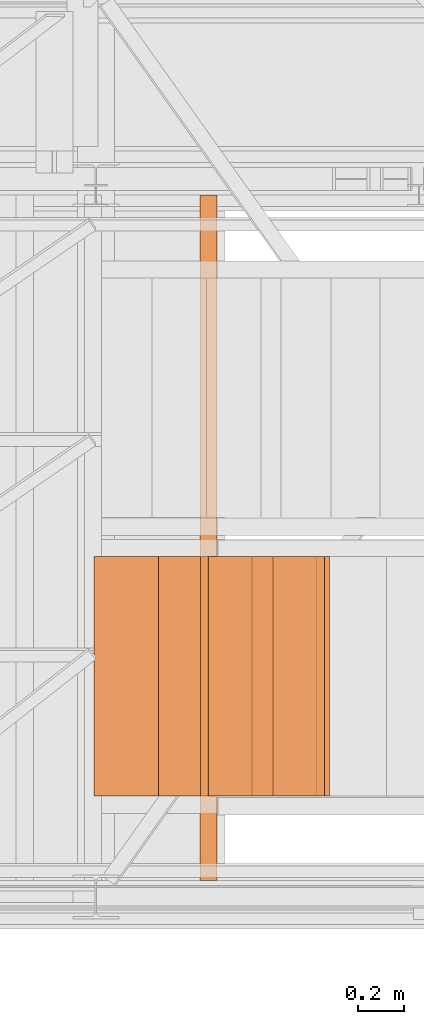
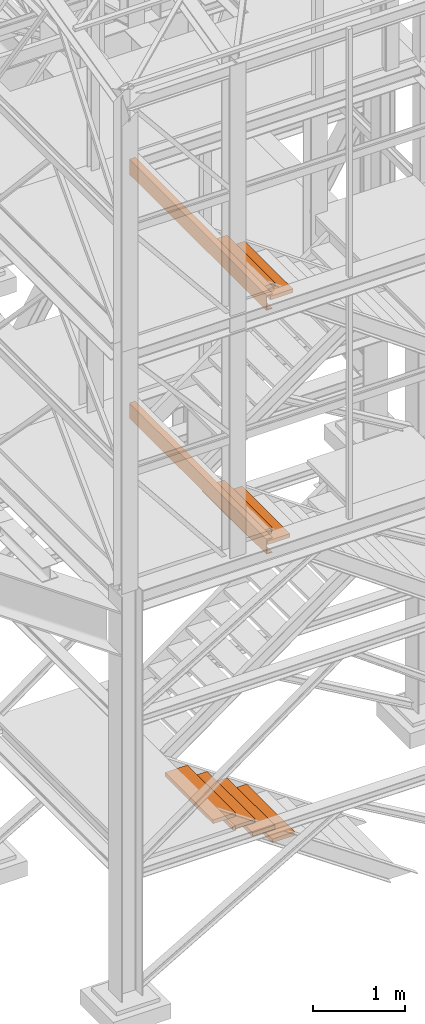
# One storey, part 10 of 208: 10 proxies.
"""IFC2X3 building model written with IfcOpenShell, lengths in millimetres."""

from ifc_helpers import new_model, entity, si_unit, converted_unit, frame, origin, origin_with_axes, place, context, subcontext, project, spatial, faceted_brep, element, save


model = new_model("IFC2X3")

# Units and contexts
model_context = context("Model", 3, precision=1e-05, world=origin())
plan_context = context("Plan", 3, precision=1e-05, world=origin())
body_context = subcontext(model_context, "Body", "Model", "MODEL_VIEW")
ifc_project = project(units=[si_unit("LENGTHUNIT", "METRE", prefix="MILLI"), converted_unit("PLANEANGLEUNIT", "DEGREE", entity("IfcPlaneAngleMeasure", 0.0174532925199433), si_unit("PLANEANGLEUNIT", "RADIAN"), dimensions=[0, 0, 0, 0, 0, 0, 0]), si_unit("AREAUNIT", "SQUARE_METRE"), si_unit("VOLUMEUNIT", "CUBIC_METRE")], contexts=[model_context, plan_context])

# Building, storey
building_placement = place(None, origin())
building = spatial("IfcBuilding", under=ifc_project, at=building_placement, CompositionType="COMPLEX")
storey_placement = place(building_placement, origin_with_axes())
storey = spatial("IfcBuildingStorey", under=building, at=storey_placement, Name="Geschoss", CompositionType="ELEMENT")

# Proxies
proxy_1_placement = place(storey_placement, frame((2998.108527679629, -25102.57439001986, 5049.989998509882), z_axis=(0.0, 0.0, 1.0), x_axis=(1.0, 0.0, 0.0)))
element("IfcBuildingElementProxy", 1, at=proxy_1_placement, inside=storey, context=body_context, shape_type="Brep", body=[
    faceted_brep([(0.01000000000021828, 2970.009999403952, 200.0100029802325), (0.01000000000021828, 2970.009999403952, 0.01000000000021828), (75.01000111758731, 2970.009999403952, 0.01000000000021828), (75.01000111758731, 2970.009999403952, 2.97083092689536), (73.89400100171588, 2970.009999403952, 7.368834147453526), (69.48847269475482, 2970.009999403952, 8.951724896431188), (19.09293180167697, 2970.009999403952, 12.98336816787742), (13.35380079060815, 2970.009999403952, 14.57858962774299), (9.50015002697728, 2970.009999403952, 18.85888857603095), (8.510000461936215, 2970.009999403952, 24.44674206733725), (8.510000461936215, 2970.009999403952, 175.5732609128954), (9.50015002697728, 2970.009999403952, 181.1611144042017), (13.35380079060815, 2970.009999403952, 185.4414133524897), (19.09293180167697, 2970.009999403952, 187.0366348123553), (69.48847269475482, 2970.009999403952, 191.0682780838015), (73.89400100171588, 2970.009999403952, 192.6511688327792), (75.01000111758731, 2970.009999403952, 197.0491720533373), (75.01000111758731, 2970.009999403952, 200.0100029802325), (0.01000000000021828, 2970.009999403952, 0.01000000000021828), (0.01000000000021828, 2970.009999403952, 200.0100029802325), (0.01000000000021828, 0.01000000000203727, 200.0100029802325), (0.01000000000021828, 0.01000000000203727, 0.01000000000021828), (75.01000111758731, 2970.009999403952, 0.01000000000021828), (0.01000000000021828, 2970.009999403952, 0.01000000000021828), (0.01000000000021828, 0.01000000000203727, 0.01000000000021828), (75.01000111758731, 0.01000000000203727, 0.01000000000021828), (75.01000111758731, 2970.009999403952, 2.97083092689536), (75.01000111758731, 2970.009999403952, 0.01000000000021828), (75.01000111758731, 0.01000000000203727, 0.01000000000021828), (75.01000111758731, 0.01000000000203727, 2.97083092689536), (73.89400100171588, 2970.009999403952, 7.368834147453526), (75.01000111758731, 2970.009999403952, 2.97083092689536), (75.01000111758731, 0.01000000000203727, 2.97083092689536), (73.89400100171588, 0.01000000000203727, 7.368834147453526), (69.48847269475482, 2970.009999403952, 8.951724896431188), (73.89400100171588, 2970.009999403952, 7.368834147453526), (73.89400100171588, 0.01000000000203727, 7.368834147453526), (69.48847269475482, 0.01000000000203727, 8.951724896431188), (19.09293180167697, 2970.009999403952, 12.98336816787742), (69.48847269475482, 2970.009999403952, 8.951724896431188), (69.48847269475482, 0.01000000000203727, 8.951724896431188), (19.09293180167697, 0.01000000000203727, 12.98336816787742), (13.35380079060815, 2970.009999403952, 14.57858962774299), (19.09293180167697, 2970.009999403952, 12.98336816787742), (19.09293180167697, 0.01000000000203727, 12.98336816787742), (13.35380079060815, 0.01000000000203727, 14.57858962774299), (9.50015002697728, 2970.009999403952, 18.85888857603095), (13.35380079060815, 2970.009999403952, 14.57858962774299), (13.35380079060815, 0.01000000000203727, 14.57858962774299), (9.50015002697728, 0.01000000000203727, 18.85888857603095), (8.510000461936215, 2970.009999403952, 24.44674206733725), (9.50015002697728, 2970.009999403952, 18.85888857603095), (9.50015002697728, 0.01000000000203727, 18.85888857603095), (8.510000461936215, 0.01000000000203727, 24.44674206733725), (8.510000461936215, 2970.009999403952, 175.5732609128954), (8.510000461936215, 2970.009999403952, 24.44674206733725), (8.510000461936215, 0.01000000000203727, 24.44674206733725), (8.510000461936215, 0.01000000000203727, 175.5732609128954), (9.50015002697728, 2970.009999403952, 181.1611144042017), (8.510000461936215, 2970.009999403952, 175.5732609128954), (8.510000461936215, 0.01000000000203727, 175.5732609128954), (9.50015002697728, 0.01000000000203727, 181.1611144042017), (13.35380079060815, 2970.009999403952, 185.4414133524897), (9.50015002697728, 2970.009999403952, 181.1611144042017), (9.50015002697728, 0.01000000000203727, 181.1611144042017), (13.35380079060815, 0.01000000000203727, 185.4414133524897), (19.09293180167697, 2970.009999403952, 187.0366348123553), (13.35380079060815, 2970.009999403952, 185.4414133524897), (13.35380079060815, 0.01000000000203727, 185.4414133524897), (19.09293180167697, 0.01000000000203727, 187.0366348123553), (69.48847269475482, 2970.009999403952, 191.0682780838015), (19.09293180167697, 2970.009999403952, 187.0366348123553), (19.09293180167697, 0.01000000000203727, 187.0366348123553), (69.48847269475482, 0.01000000000203727, 191.0682780838015), (73.89400100171588, 2970.009999403952, 192.6511688327792), (69.48847269475482, 2970.009999403952, 191.0682780838015), (69.48847269475482, 0.01000000000203727, 191.0682780838015), (73.89400100171588, 0.01000000000203727, 192.6511688327792), (75.01000111758731, 2970.009999403952, 197.0491720533373), (73.89400100171588, 2970.009999403952, 192.6511688327792), (73.89400100171588, 0.01000000000203727, 192.6511688327792), (75.01000111758731, 0.01000000000203727, 197.0491720533373), (75.01000111758731, 2970.009999403952, 200.0100029802325), (75.01000111758731, 2970.009999403952, 197.0491720533373), (75.01000111758731, 0.01000000000203727, 197.0491720533373), (75.01000111758731, 0.01000000000203727, 200.0100029802325), (0.01000000000021828, 2970.009999403952, 200.0100029802325), (75.01000111758731, 2970.009999403952, 200.0100029802325), (75.01000111758731, 0.01000000000203727, 200.0100029802325), (0.01000000000021828, 0.01000000000203727, 200.0100029802325), (0.01000000000021828, 0.01000000000203727, 200.0100029802325), (75.01000111758731, 0.01000000000203727, 200.0100029802325), (75.01000111758731, 0.01000000000203727, 197.0491720533373), (73.89400100171588, 0.01000000000203727, 192.6511688327792), (69.48847269475482, 0.01000000000203727, 191.0682780838015), (19.09293180167697, 0.01000000000203727, 187.0366348123553), (13.35380079060815, 0.01000000000203727, 185.4414133524897), (9.50015002697728, 0.01000000000203727, 181.1611144042017), (8.510000461936215, 0.01000000000203727, 175.5732609128954), (8.510000461936215, 0.01000000000203727, 24.44674206733725), (9.50015002697728, 0.01000000000203727, 18.85888857603095), (13.35380079060815, 0.01000000000203727, 14.57858962774299), (19.09293180167697, 0.01000000000203727, 12.98336816787742), (69.48847269475482, 0.01000000000203727, 8.951724896431188), (73.89400100171588, 0.01000000000203727, 7.368834147453526), (75.01000111758731, 0.01000000000203727, 2.97083092689536), (75.01000111758731, 0.01000000000203727, 0.01000000000021828), (0.01000000000021828, 0.01000000000203727, 0.01000000000021828)], [[[0, 1, 2, 3, 4, 5, 6, 7, 8, 9, 10, 11, 12, 13, 14, 15, 16, 17]], [[18, 19, 20, 21]], [[22, 23, 24, 25]], [[26, 27, 28, 29]], [[30, 31, 32, 33]], [[34, 35, 36, 37]], [[38, 39, 40, 41]], [[42, 43, 44, 45]], [[46, 47, 48, 49]], [[50, 51, 52, 53]], [[54, 55, 56, 57]], [[58, 59, 60, 61]], [[62, 63, 64, 65]], [[66, 67, 68, 69]], [[70, 71, 72, 73]], [[74, 75, 76, 77]], [[78, 79, 80, 81]], [[82, 83, 84, 85]], [[86, 87, 88, 89]], [[90, 91, 92, 93, 94, 95, 96, 97, 98, 99, 100, 101, 102, 103, 104, 105, 106, 107]]], orient=[[False], [False], [False], [False], [False], [False], [False], [False], [False], [False], [False], [False], [False], [False], [False], [False], [False], [False], [False], [False]]),
])
for number, where, z_axis, x_axis in (
    (2, (3281.72670904966, -24736.51916887601, 919.9900010557137), (0.0, 0.0, 1.0), (1.0, 0.0, 0.0)),
    (3, (3034.506000078644, -24736.51916887601, 1089.990001055714), (0.0, 0.0, 1.0), (1.0, 0.0, 0.0)),
    (4, (2787.285291107629, -24736.51916887601, 1259.990001055714), (0.0, 0.0, 1.0), (1.0, 0.0, 0.0)),
    (5, (2540.064582136613, -24736.51916887601, 1429.990001055713), (0.0, 0.0, 1.0), (1.0, 0.0, 0.0)),
):
    element("IfcBuildingElementProxy", number, at=place(storey_placement, frame(where, z_axis=z_axis, x_axis=x_axis)), inside=storey, context=body_context, shape_type="Brep", body=[
        faceted_brep([(0.01000000000021828, 0.00999999999839929, 0.009999999999990905), (280.2746556316183, 0.00999999999839929, 0.009999999999990905), (280.2746556316183, 1037.717170711916, 0.009999999999990905), (0.01000000000021828, 1037.717170711916, 0.009999999999990905), (280.2746556316183, 0.00999999999839929, 50.00999999999999), (0.01000000000021828, 0.00999999999839929, 50.00999999999999), (0.01000000000021828, 1037.717170711916, 50.00999999999999), (280.2746556316183, 1037.717170711916, 50.00999999999999), (280.2746556316183, 0.00999999999839929, 0.009999999999990905), (0.01000000000021828, 0.00999999999839929, 0.009999999999990905), (0.01000000000021828, 0.00999999999839929, 50.00999999999999), (280.2746556316183, 0.00999999999839929, 50.00999999999999), (280.2746556316183, 1037.717170711916, 0.009999999999990905), (280.2746556316183, 0.00999999999839929, 0.009999999999990905), (280.2746556316183, 0.00999999999839929, 50.00999999999999), (280.2746556316183, 1037.717170711916, 50.00999999999999), (0.01000000000021828, 1037.717170711916, 0.009999999999990905), (280.2746556316183, 1037.717170711916, 0.009999999999990905), (280.2746556316183, 1037.717170711916, 50.00999999999999), (0.01000000000021828, 1037.717170711916, 50.00999999999999), (0.01000000000021828, 0.00999999999839929, 0.009999999999990905), (0.01000000000021828, 1037.717170711916, 0.009999999999990905), (0.01000000000021828, 1037.717170711916, 50.00999999999999), (0.01000000000021828, 0.00999999999839929, 50.00999999999999)], [[[0, 1, 2, 3]], [[4, 5, 6, 7]], [[8, 9, 10, 11]], [[12, 13, 14, 15]], [[16, 17, 18, 19]], [[20, 21, 22, 23]]], orient=[[False], [False], [False], [False], [False], [False]]),
    ])
for number, where, z_axis, x_axis in (
    (6, (3223.286924024275, -24736.51916887601, 4877.039372824652), (0.0, 0.0, 1.0), (1.0, 0.0, 0.0)),
    (7, (3000.433130265476, -24736.51916887601, 5035.803639005839), (0.0, 0.0, 1.0), (1.0, 0.0, 0.0)),
):
    element("IfcBuildingElementProxy", number, at=place(storey_placement, frame(where, z_axis=z_axis, x_axis=x_axis)), inside=storey, context=body_context, shape_type="Brep", body=[
        faceted_brep([(0.01000000000021828, 0.00999999999839929, 0.01000000000021828), (280.2746556316183, 0.00999999999839929, 0.01000000000021828), (280.2746556316183, 1037.717170711916, 0.01000000000021828), (0.01000000000021828, 1037.717170711916, 0.01000000000021828), (280.2746556316183, 0.00999999999839929, 50.01000000000022), (0.01000000000021828, 0.00999999999839929, 50.01000000000022), (0.01000000000021828, 1037.717170711916, 50.01000000000022), (280.2746556316183, 1037.717170711916, 50.01000000000022), (280.2746556316183, 0.00999999999839929, 0.01000000000021828), (0.01000000000021828, 0.00999999999839929, 0.01000000000021828), (0.01000000000021828, 0.00999999999839929, 50.01000000000022), (280.2746556316183, 0.00999999999839929, 50.01000000000022), (280.2746556316183, 1037.717170711916, 0.01000000000021828), (280.2746556316183, 0.00999999999839929, 0.01000000000021828), (280.2746556316183, 0.00999999999839929, 50.01000000000022), (280.2746556316183, 1037.717170711916, 50.01000000000022), (0.01000000000021828, 1037.717170711916, 0.01000000000021828), (280.2746556316183, 1037.717170711916, 0.01000000000021828), (280.2746556316183, 1037.717170711916, 50.01000000000022), (0.01000000000021828, 1037.717170711916, 50.01000000000022), (0.01000000000021828, 0.00999999999839929, 0.01000000000021828), (0.01000000000021828, 1037.717170711916, 0.01000000000021828), (0.01000000000021828, 1037.717170711916, 50.01000000000022), (0.01000000000021828, 0.00999999999839929, 50.01000000000022)], [[[0, 1, 2, 3]], [[4, 5, 6, 7]], [[8, 9, 10, 11]], [[12, 13, 14, 15]], [[16, 17, 18, 19]], [[20, 21, 22, 23]]], orient=[[False], [False], [False], [False], [False], [False]]),
    ])
proxy_2_placement = place(storey_placement, frame((2998.108527679629, -25102.57439001986, 8269.989998509878), z_axis=(0.0, 0.0, 1.0), x_axis=(1.0, 0.0, 0.0)))
element("IfcBuildingElementProxy", 8, at=proxy_2_placement, inside=storey, context=body_context, shape_type="Brep", body=[
    faceted_brep([(0.01000000000021828, 2970.009999403952, 200.0100029802325), (0.01000000000021828, 2970.009999403952, 0.01000000000021828), (75.01000111758731, 2970.009999403952, 0.01000000000021828), (75.01000111758731, 2970.009999403952, 2.97083092689536), (73.89400100171588, 2970.009999403952, 7.368834147453526), (69.48847269475482, 2970.009999403952, 8.951724896431188), (19.09293180167697, 2970.009999403952, 12.98336816787742), (13.35380079060815, 2970.009999403952, 14.57858962774299), (9.50015002697728, 2970.009999403952, 18.85888857603095), (8.510000461936215, 2970.009999403952, 24.44674206733725), (8.510000461936215, 2970.009999403952, 175.5732609128954), (9.50015002697728, 2970.009999403952, 181.1611144042017), (13.35380079060815, 2970.009999403952, 185.4414133524897), (19.09293180167697, 2970.009999403952, 187.0366348123553), (69.48847269475482, 2970.009999403952, 191.0682780838015), (73.89400100171588, 2970.009999403952, 192.6511688327792), (75.01000111758731, 2970.009999403952, 197.0491720533373), (75.01000111758731, 2970.009999403952, 200.0100029802325), (0.01000000000021828, 2970.009999403952, 0.01000000000021828), (0.01000000000021828, 2970.009999403952, 200.0100029802325), (0.01000000000021828, 0.01000000000203727, 200.0100029802325), (0.01000000000021828, 0.01000000000203727, 0.01000000000021828), (75.01000111758731, 2970.009999403952, 0.01000000000021828), (0.01000000000021828, 2970.009999403952, 0.01000000000021828), (0.01000000000021828, 0.01000000000203727, 0.01000000000021828), (75.01000111758731, 0.01000000000203727, 0.01000000000021828), (75.01000111758731, 2970.009999403952, 2.97083092689536), (75.01000111758731, 2970.009999403952, 0.01000000000021828), (75.01000111758731, 0.01000000000203727, 0.01000000000021828), (75.01000111758731, 0.01000000000203727, 2.97083092689536), (73.89400100171588, 2970.009999403952, 7.368834147453526), (75.01000111758731, 2970.009999403952, 2.97083092689536), (75.01000111758731, 0.01000000000203727, 2.97083092689536), (73.89400100171588, 0.01000000000203727, 7.368834147453526), (69.48847269475482, 2970.009999403952, 8.951724896431188), (73.89400100171588, 2970.009999403952, 7.368834147453526), (73.89400100171588, 0.01000000000203727, 7.368834147453526), (69.48847269475482, 0.01000000000203727, 8.951724896431188), (19.09293180167697, 2970.009999403952, 12.98336816787742), (69.48847269475482, 2970.009999403952, 8.951724896431188), (69.48847269475482, 0.01000000000203727, 8.951724896431188), (19.09293180167697, 0.01000000000203727, 12.98336816787742), (13.35380079060815, 2970.009999403952, 14.57858962774299), (19.09293180167697, 2970.009999403952, 12.98336816787742), (19.09293180167697, 0.01000000000203727, 12.98336816787742), (13.35380079060815, 0.01000000000203727, 14.57858962774299), (9.50015002697728, 2970.009999403952, 18.85888857603095), (13.35380079060815, 2970.009999403952, 14.57858962774299), (13.35380079060815, 0.01000000000203727, 14.57858962774299), (9.50015002697728, 0.01000000000203727, 18.85888857603095), (8.510000461936215, 2970.009999403952, 24.44674206733725), (9.50015002697728, 2970.009999403952, 18.85888857603095), (9.50015002697728, 0.01000000000203727, 18.85888857603095), (8.510000461936215, 0.01000000000203727, 24.44674206733725), (8.510000461936215, 2970.009999403952, 175.5732609128954), (8.510000461936215, 2970.009999403952, 24.44674206733725), (8.510000461936215, 0.01000000000203727, 24.44674206733725), (8.510000461936215, 0.01000000000203727, 175.5732609128954), (9.50015002697728, 2970.009999403952, 181.1611144042017), (8.510000461936215, 2970.009999403952, 175.5732609128954), (8.510000461936215, 0.01000000000203727, 175.5732609128954), (9.50015002697728, 0.01000000000203727, 181.1611144042017), (13.35380079060815, 2970.009999403952, 185.4414133524897), (9.50015002697728, 2970.009999403952, 181.1611144042017), (9.50015002697728, 0.01000000000203727, 181.1611144042017), (13.35380079060815, 0.01000000000203727, 185.4414133524897), (19.09293180167697, 2970.009999403952, 187.0366348123553), (13.35380079060815, 2970.009999403952, 185.4414133524897), (13.35380079060815, 0.01000000000203727, 185.4414133524897), (19.09293180167697, 0.01000000000203727, 187.0366348123553), (69.48847269475482, 2970.009999403952, 191.0682780838015), (19.09293180167697, 2970.009999403952, 187.0366348123553), (19.09293180167697, 0.01000000000203727, 187.0366348123553), (69.48847269475482, 0.01000000000203727, 191.0682780838015), (73.89400100171588, 2970.009999403952, 192.6511688327792), (69.48847269475482, 2970.009999403952, 191.0682780838015), (69.48847269475482, 0.01000000000203727, 191.0682780838015), (73.89400100171588, 0.01000000000203727, 192.6511688327792), (75.01000111758731, 2970.009999403952, 197.0491720533373), (73.89400100171588, 2970.009999403952, 192.6511688327792), (73.89400100171588, 0.01000000000203727, 192.6511688327792), (75.01000111758731, 0.01000000000203727, 197.0491720533373), (75.01000111758731, 2970.009999403952, 200.0100029802325), (75.01000111758731, 2970.009999403952, 197.0491720533373), (75.01000111758731, 0.01000000000203727, 197.0491720533373), (75.01000111758731, 0.01000000000203727, 200.0100029802325), (0.01000000000021828, 2970.009999403952, 200.0100029802325), (75.01000111758731, 2970.009999403952, 200.0100029802325), (75.01000111758731, 0.01000000000203727, 200.0100029802325), (0.01000000000021828, 0.01000000000203727, 200.0100029802325), (0.01000000000021828, 0.01000000000203727, 200.0100029802325), (75.01000111758731, 0.01000000000203727, 200.0100029802325), (75.01000111758731, 0.01000000000203727, 197.0491720533373), (73.89400100171588, 0.01000000000203727, 192.6511688327792), (69.48847269475482, 0.01000000000203727, 191.0682780838015), (19.09293180167697, 0.01000000000203727, 187.0366348123553), (13.35380079060815, 0.01000000000203727, 185.4414133524897), (9.50015002697728, 0.01000000000203727, 181.1611144042017), (8.510000461936215, 0.01000000000203727, 175.5732609128954), (8.510000461936215, 0.01000000000203727, 24.44674206733725), (9.50015002697728, 0.01000000000203727, 18.85888857603095), (13.35380079060815, 0.01000000000203727, 14.57858962774299), (19.09293180167697, 0.01000000000203727, 12.98336816787742), (69.48847269475482, 0.01000000000203727, 8.951724896431188), (73.89400100171588, 0.01000000000203727, 7.368834147453526), (75.01000111758731, 0.01000000000203727, 2.97083092689536), (75.01000111758731, 0.01000000000203727, 0.01000000000021828), (0.01000000000021828, 0.01000000000203727, 0.01000000000021828)], [[[0, 1, 2, 3, 4, 5, 6, 7, 8, 9, 10, 11, 12, 13, 14, 15, 16, 17]], [[18, 19, 20, 21]], [[22, 23, 24, 25]], [[26, 27, 28, 29]], [[30, 31, 32, 33]], [[34, 35, 36, 37]], [[38, 39, 40, 41]], [[42, 43, 44, 45]], [[46, 47, 48, 49]], [[50, 51, 52, 53]], [[54, 55, 56, 57]], [[58, 59, 60, 61]], [[62, 63, 64, 65]], [[66, 67, 68, 69]], [[70, 71, 72, 73]], [[74, 75, 76, 77]], [[78, 79, 80, 81]], [[82, 83, 84, 85]], [[86, 87, 88, 89]], [[90, 91, 92, 93, 94, 95, 96, 97, 98, 99, 100, 101, 102, 103, 104, 105, 106, 107]]], orient=[[False], [False], [False], [False], [False], [False], [False], [False], [False], [False], [False], [False], [False], [False], [False], [False], [False], [False], [False], [False]]),
])
for number, where, z_axis, x_axis in (
    (9, (3258.286924024275, -24736.51916887601, 8097.001603097988), (0.0, 0.0, 1.0), (1.0, 0.0, 0.0)),
    (10, (3035.433130265476, -24736.51916887601, 8255.765869279174), (0.0, 0.0, 1.0), (1.0, 0.0, 0.0)),
):
    element("IfcBuildingElementProxy", number, at=place(storey_placement, frame(where, z_axis=z_axis, x_axis=x_axis)), inside=storey, context=body_context, shape_type="Brep", body=[
        faceted_brep([(0.01000000000021828, 0.00999999999839929, 0.01000000000021828), (280.2746556316183, 0.00999999999839929, 0.01000000000021828), (280.2746556316183, 1037.717170711916, 0.01000000000021828), (0.01000000000021828, 1037.717170711916, 0.01000000000021828), (280.2746556316183, 0.00999999999839929, 50.01000000000022), (0.01000000000021828, 0.00999999999839929, 50.01000000000022), (0.01000000000021828, 1037.717170711916, 50.01000000000022), (280.2746556316183, 1037.717170711916, 50.01000000000022), (280.2746556316183, 0.00999999999839929, 0.01000000000021828), (0.01000000000021828, 0.00999999999839929, 0.01000000000021828), (0.01000000000021828, 0.00999999999839929, 50.01000000000022), (280.2746556316183, 0.00999999999839929, 50.01000000000022), (280.2746556316183, 1037.717170711916, 0.01000000000021828), (280.2746556316183, 0.00999999999839929, 0.01000000000021828), (280.2746556316183, 0.00999999999839929, 50.01000000000022), (280.2746556316183, 1037.717170711916, 50.01000000000022), (0.01000000000021828, 1037.717170711916, 0.01000000000021828), (280.2746556316183, 1037.717170711916, 0.01000000000021828), (280.2746556316183, 1037.717170711916, 50.01000000000022), (0.01000000000021828, 1037.717170711916, 50.01000000000022), (0.01000000000021828, 0.00999999999839929, 0.01000000000021828), (0.01000000000021828, 1037.717170711916, 0.01000000000021828), (0.01000000000021828, 1037.717170711916, 50.01000000000022), (0.01000000000021828, 0.00999999999839929, 50.01000000000022)], [[[0, 1, 2, 3]], [[4, 5, 6, 7]], [[8, 9, 10, 11]], [[12, 13, 14, 15]], [[16, 17, 18, 19]], [[20, 21, 22, 23]]], orient=[[False], [False], [False], [False], [False], [False]]),
    ])

save(model, "model.ifc")
